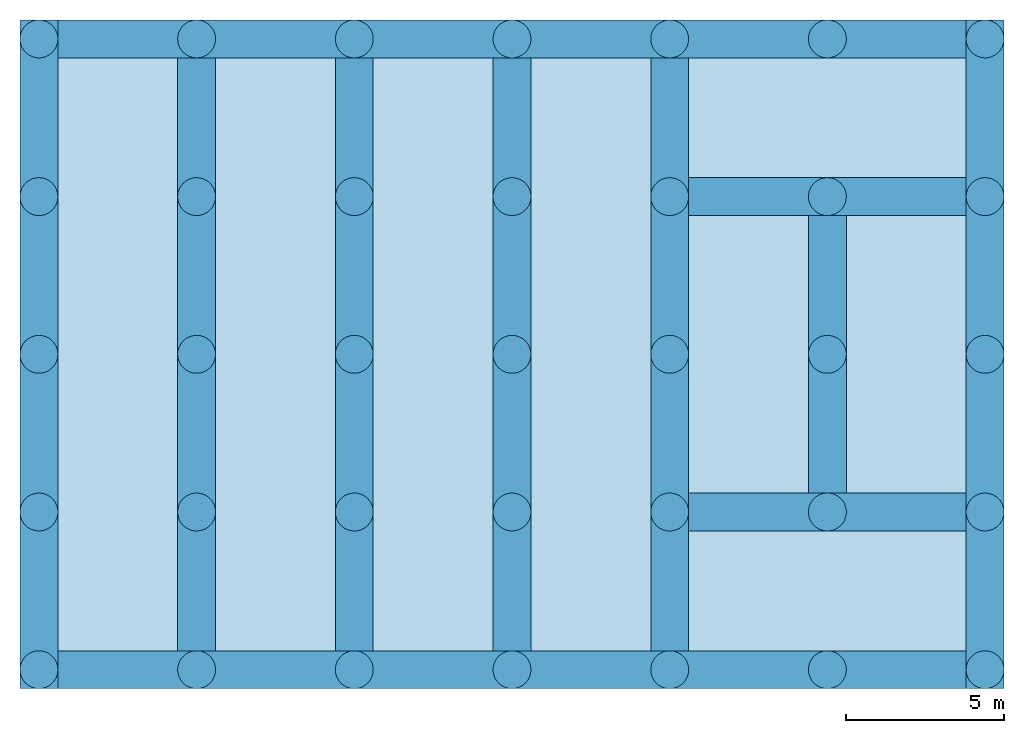
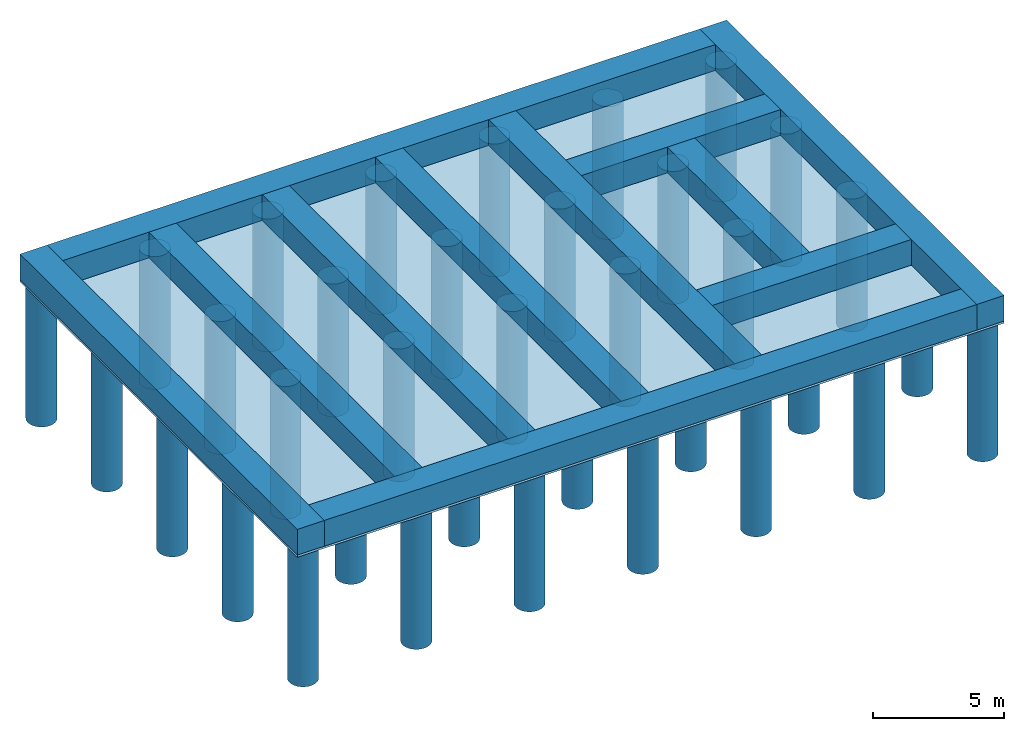
# One storey: 46 footings, 1 slab.
"""IFC2X3 building model written with IfcOpenShell, lengths in metres."""

from ifc_helpers import new_model, entity, si_unit, converted_unit, frame, frame_2d, origin, origin_with_axes, place, context, subcontext, project, spatial, rectangle, circle, extrude, material, element, save


model = new_model("IFC2X3")

# Units and contexts
model_context = context("Model", 3, precision=1e-05, world=origin())
body_context = subcontext(model_context, "Body", "Model", "MODEL_VIEW")
ifc_project = project(units=[si_unit("LENGTHUNIT", "METRE"), si_unit("AREAUNIT", "SQUARE_METRE"), si_unit("VOLUMEUNIT", "CUBIC_METRE"), si_unit("MASSUNIT", "GRAM", prefix="KILO"), converted_unit("PLANEANGLEUNIT", "DEGREE", entity("IfcPlaneAngleMeasure", 0.0174532925199433), si_unit("PLANEANGLEUNIT", "RADIAN"), dimensions=[0, 0, 0, 0, 0, 0, 0])], contexts=[model_context])

# Site, building, storey
site_placement = place(None, origin())
site = spatial("IfcSite", under=ifc_project, at=site_placement, CompositionType="ELEMENT")
building_placement = place(site_placement, origin())
building = spatial("IfcBuilding", under=site, at=building_placement, CompositionType="ELEMENT")
storey_placement = place(building_placement, frame((0.0, 0.0, -4.7)))
storey = spatial("IfcBuildingStorey", under=building, at=storey_placement, CompositionType="ELEMENT", Elevation=-4.7)

# Footings
ifc_material_1 = material(Name="C25/30")
footing_1_placement = place(storey_placement, frame((0.8, 19.6, 0.0)))
element("IfcFooting", 1, at=footing_1_placement, inside=storey, material=ifc_material_1, PredefinedType="STRIP_FOOTING", context=body_context, shape_type="SweptSolid", body=[
    extrude(rectangle(XDim=1.2, YDim=1.2, at=frame_2d((0.6, 0.6), x_axis=(1.0, 0.0))), frame((0.0, 0.0, 0.0), z_axis=(1.0, 0.0, 0.0), x_axis=(0.0, 1.0, 0.0)), (0.0, 0.0, 1.0), 28.8),
])
ifc_material_2 = material(Name="C25/30")
footing_2_placement = place(storey_placement, frame((0.8, -0.4, 0.0), z_axis=(0.0, 0.0, 1.0), x_axis=(0.0, 1.0, 0.0)))
element("IfcFooting", 2, at=footing_2_placement, inside=storey, material=ifc_material_2, PredefinedType="STRIP_FOOTING", context=body_context, shape_type="SweptSolid", body=[
    extrude(rectangle(XDim=1.2, YDim=1.2, at=frame_2d((0.6, 0.6), x_axis=(1.0, 0.0))), frame((0.0, 0.0, 0.0), z_axis=(1.0, 0.0, 0.0), x_axis=(0.0, 1.0, 0.0)), (0.0, 0.0, 1.0), 21.2),
])
ifc_material_3 = material(Name="C25/30")
footing_3_placement = place(storey_placement, frame((29.6, 0.8, 0.0), z_axis=(0.0, 0.0, 1.0), x_axis=(-1.0, 0.0, 0.0)))
element("IfcFooting", 3, at=footing_3_placement, inside=storey, material=ifc_material_3, PredefinedType="STRIP_FOOTING", context=body_context, shape_type="SweptSolid", body=[
    extrude(rectangle(XDim=1.2, YDim=1.2, at=frame_2d((0.6, 0.6), x_axis=(1.0, 0.0))), frame((0.0, 0.0, 0.0), z_axis=(1.0, 0.0, 0.0), x_axis=(0.0, 1.0, 0.0)), (0.0, 0.0, 1.0), 28.8),
])
ifc_material_4 = material(Name="C25/30")
footing_4_placement = place(storey_placement, frame((29.6, 20.8, 0.0), z_axis=(0.0, 0.0, 1.0), x_axis=(0.0, -1.0, 0.0)))
element("IfcFooting", 4, at=footing_4_placement, inside=storey, material=ifc_material_4, PredefinedType="STRIP_FOOTING", context=body_context, shape_type="SweptSolid", body=[
    extrude(rectangle(XDim=1.2, YDim=1.2, at=frame_2d((0.6, 0.6), x_axis=(1.0, 0.0))), frame((0.0, 0.0, 0.0), z_axis=(1.0, 0.0, 0.0), x_axis=(0.0, 1.0, 0.0)), (0.0, 0.0, 1.0), 21.2),
])
ifc_material_5 = material(Name="C25/30")
footing_5_placement = place(storey_placement, frame((20.8, 0.8, 0.0), z_axis=(0.0, 0.0, 1.0), x_axis=(0.0, 1.0, 0.0)))
element("IfcFooting", 5, at=footing_5_placement, inside=storey, material=ifc_material_5, PredefinedType="STRIP_FOOTING", context=body_context, shape_type="SweptSolid", body=[
    extrude(rectangle(XDim=1.2, YDim=1.2, at=frame_2d((0.6, 0.6), x_axis=(1.0, 0.0))), frame((0.0, 0.0, 0.0), z_axis=(1.0, 0.0, 0.0), x_axis=(0.0, 1.0, 0.0)), (0.0, 0.0, 1.0), 18.8),
])
ifc_material_6 = material(Name="C25/30")
footing_6_placement = place(storey_placement, frame((15.8, 0.8, 0.0), z_axis=(0.0, 0.0, 1.0), x_axis=(0.0, 1.0, 0.0)))
element("IfcFooting", 6, at=footing_6_placement, inside=storey, material=ifc_material_6, PredefinedType="STRIP_FOOTING", context=body_context, shape_type="SweptSolid", body=[
    extrude(rectangle(XDim=1.2, YDim=1.2, at=frame_2d((0.6, 0.6), x_axis=(1.0, 0.0))), frame((0.0, 0.0, 0.0), z_axis=(1.0, 0.0, 0.0), x_axis=(0.0, 1.0, 0.0)), (0.0, 0.0, 1.0), 18.8),
])
ifc_material_7 = material(Name="C25/30")
footing_7_placement = place(storey_placement, frame((10.8, 0.8, 0.0), z_axis=(0.0, 0.0, 1.0), x_axis=(0.0, 1.0, 0.0)))
element("IfcFooting", 7, at=footing_7_placement, inside=storey, material=ifc_material_7, PredefinedType="STRIP_FOOTING", context=body_context, shape_type="SweptSolid", body=[
    extrude(rectangle(XDim=1.2, YDim=1.2, at=frame_2d((0.600000000000002, 0.6), x_axis=(1.0, 0.0))), frame((0.0, 0.0, 0.0), z_axis=(1.0, 0.0, 0.0), x_axis=(0.0, 1.0, 0.0)), (0.0, 0.0, 1.0), 18.8),
])
ifc_material_8 = material(Name="C25/30")
footing_8_placement = place(storey_placement, frame((5.8, 0.8, 0.0), z_axis=(0.0, 0.0, 1.0), x_axis=(0.0, 1.0, 0.0)))
element("IfcFooting", 8, at=footing_8_placement, inside=storey, material=ifc_material_8, PredefinedType="STRIP_FOOTING", context=body_context, shape_type="SweptSolid", body=[
    extrude(rectangle(XDim=1.2, YDim=1.2, at=frame_2d((0.6, 0.6), x_axis=(1.0, 0.0))), frame((0.0, 0.0, 0.0), z_axis=(1.0, 0.0, 0.0), x_axis=(0.0, 1.0, 0.0)), (0.0, 0.0, 1.0), 18.8),
])
ifc_material_9 = material(Name="C25/30")
footing_9_placement = place(storey_placement, frame((24.6, 14.6, 0.0), z_axis=(0.0, 0.0, 1.0), x_axis=(0.0, -1.0, 0.0)))
element("IfcFooting", 9, at=footing_9_placement, inside=storey, material=ifc_material_9, PredefinedType="STRIP_FOOTING", context=body_context, shape_type="SweptSolid", body=[
    extrude(rectangle(XDim=1.2, YDim=1.2, at=frame_2d((0.6, 0.6), x_axis=(1.0, 0.0))), frame((0.0, 0.0, 0.0), z_axis=(1.0, 0.0, 0.0), x_axis=(0.0, 1.0, 0.0)), (0.0, 0.0, 1.0), 8.8),
])
ifc_material_10 = material(Name="C25/30")
footing_10_placement = place(storey_placement, frame((29.6, 5.8, 0.0), z_axis=(0.0, 0.0, 1.0), x_axis=(-1.0, 0.0, 0.0)))
element("IfcFooting", 10, at=footing_10_placement, inside=storey, material=ifc_material_10, PredefinedType="STRIP_FOOTING", context=body_context, shape_type="SweptSolid", body=[
    extrude(rectangle(XDim=1.2, YDim=1.2, at=frame_2d((0.6, 0.6), x_axis=(1.0, 0.0))), frame((0.0, 0.0, 0.0), z_axis=(1.0, 0.0, 0.0), x_axis=(0.0, 1.0, 0.0)), (0.0, 0.0, 1.0), 8.8),
])
ifc_material_11 = material(Name="C25/30")
footing_11_placement = place(storey_placement, frame((20.8, 14.6, 0.0)))
element("IfcFooting", 11, at=footing_11_placement, inside=storey, material=ifc_material_11, PredefinedType="STRIP_FOOTING", context=body_context, shape_type="SweptSolid", body=[
    extrude(rectangle(XDim=1.2, YDim=1.2, at=frame_2d((0.6, 0.6), x_axis=(1.0, 0.0))), frame((0.0, 0.0, 0.0), z_axis=(1.0, 0.0, 0.0), x_axis=(0.0, 1.0, 0.0)), (0.0, 0.0, 1.0), 8.8),
])
ifc_material_12 = material(Name="C25/30")
footing_12_placement = place(storey_placement, frame((9.60247658058307, 4.60247658058307, -6.3)))
element("IfcFooting", 12, at=footing_12_placement, inside=storey, material=ifc_material_12, PredefinedType="PAD_FOOTING", context=body_context, shape_type="SweptSolid", body=[
    extrude(circle(Radius=0.6, at=frame_2d((0.6, 0.6), x_axis=(1.0, 0.0))), frame((-0.00247658058306843, -0.00247658058306843, 0.0), z_axis=(0.0, 0.0, 1.0), x_axis=(1.0, 0.0, 0.0)), (0.0, 0.0, 1.0), 6.2),
])
ifc_material_13 = material(Name="C25/30")
footing_13_placement = place(storey_placement, frame((14.6024765805831, 4.60247658058307, -6.3)))
element("IfcFooting", 13, at=footing_13_placement, inside=storey, material=ifc_material_13, PredefinedType="PAD_FOOTING", context=body_context, shape_type="SweptSolid", body=[
    extrude(circle(Radius=0.6, at=frame_2d((0.6, 0.6), x_axis=(1.0, 0.0))), frame((-0.00247658058306843, -0.00247658058306843, 0.0), z_axis=(0.0, 0.0, 1.0), x_axis=(1.0, 0.0, 0.0)), (0.0, 0.0, 1.0), 6.2),
])
ifc_material_14 = material(Name="C25/30")
footing_14_placement = place(storey_placement, frame((19.6024765805831, 4.60247658058307, -6.3)))
element("IfcFooting", 14, at=footing_14_placement, inside=storey, material=ifc_material_14, PredefinedType="PAD_FOOTING", context=body_context, shape_type="SweptSolid", body=[
    extrude(circle(Radius=0.6, at=frame_2d((0.6, 0.6), x_axis=(1.0, 0.0))), frame((-0.00247658058306843, -0.00247658058306843, 0.0), z_axis=(0.0, 0.0, 1.0), x_axis=(1.0, 0.0, 0.0)), (0.0, 0.0, 1.0), 6.2),
])
ifc_material_15 = material(Name="C25/30")
footing_15_placement = place(storey_placement, frame((24.6024765805831, 4.60247658058307, -6.3)))
element("IfcFooting", 15, at=footing_15_placement, inside=storey, material=ifc_material_15, PredefinedType="PAD_FOOTING", context=body_context, shape_type="SweptSolid", body=[
    extrude(circle(Radius=0.6, at=frame_2d((0.6, 0.6), x_axis=(1.0, 0.0))), frame((-0.00247658058306843, -0.00247658058306843, 0.0), z_axis=(0.0, 0.0, 1.0), x_axis=(1.0, 0.0, 0.0)), (0.0, 0.0, 1.0), 6.2),
])
ifc_material_16 = material(Name="C25/30")
footing_16_placement = place(storey_placement, frame((29.6024765805831, 4.60247658058307, -6.3)))
element("IfcFooting", 16, at=footing_16_placement, inside=storey, material=ifc_material_16, PredefinedType="PAD_FOOTING", context=body_context, shape_type="SweptSolid", body=[
    extrude(circle(Radius=0.6, at=frame_2d((0.6, 0.6), x_axis=(1.0, 0.0))), frame((-0.00247658058306843, -0.00247658058306843, 0.0), z_axis=(0.0, 0.0, 1.0), x_axis=(1.0, 0.0, 0.0)), (0.0, 0.0, 1.0), 6.2),
])
ifc_material_17 = material(Name="C25/30")
footing_17_placement = place(storey_placement, frame((9.60247658058307, -0.397523419416931, -6.3)))
element("IfcFooting", 17, at=footing_17_placement, inside=storey, material=ifc_material_17, PredefinedType="PAD_FOOTING", context=body_context, shape_type="SweptSolid", body=[
    extrude(circle(Radius=0.6, at=frame_2d((0.6, 0.6), x_axis=(1.0, 0.0))), frame((-0.00247658058306843, -0.00247658058306877, 0.0), z_axis=(0.0, 0.0, 1.0), x_axis=(1.0, 0.0, 0.0)), (0.0, 0.0, 1.0), 6.2),
])
ifc_material_18 = material(Name="C25/30")
footing_18_placement = place(storey_placement, frame((14.6024765805831, -0.397523419416931, -6.3)))
element("IfcFooting", 18, at=footing_18_placement, inside=storey, material=ifc_material_18, PredefinedType="PAD_FOOTING", context=body_context, shape_type="SweptSolid", body=[
    extrude(circle(Radius=0.6, at=frame_2d((0.6, 0.6), x_axis=(1.0, 0.0))), frame((-0.00247658058306843, -0.00247658058306877, 0.0), z_axis=(0.0, 0.0, 1.0), x_axis=(1.0, 0.0, 0.0)), (0.0, 0.0, 1.0), 6.2),
])
ifc_material_19 = material(Name="C25/30")
footing_19_placement = place(storey_placement, frame((19.6024765805831, -0.397523419416931, -6.3)))
element("IfcFooting", 19, at=footing_19_placement, inside=storey, material=ifc_material_19, PredefinedType="PAD_FOOTING", context=body_context, shape_type="SweptSolid", body=[
    extrude(circle(Radius=0.6, at=frame_2d((0.6, 0.6), x_axis=(1.0, 0.0))), frame((-0.00247658058306843, -0.00247658058306877, 0.0), z_axis=(0.0, 0.0, 1.0), x_axis=(1.0, 0.0, 0.0)), (0.0, 0.0, 1.0), 6.2),
])
ifc_material_20 = material(Name="C25/30")
footing_20_placement = place(storey_placement, frame((24.6024765805831, -0.397523419416931, -6.3)))
element("IfcFooting", 20, at=footing_20_placement, inside=storey, material=ifc_material_20, PredefinedType="PAD_FOOTING", context=body_context, shape_type="SweptSolid", body=[
    extrude(circle(Radius=0.6, at=frame_2d((0.6, 0.6), x_axis=(1.0, 0.0))), frame((-0.00247658058306843, -0.00247658058306877, 0.0), z_axis=(0.0, 0.0, 1.0), x_axis=(1.0, 0.0, 0.0)), (0.0, 0.0, 1.0), 6.2),
])
ifc_material_21 = material(Name="C25/30")
footing_21_placement = place(storey_placement, frame((29.6024765805831, -0.397523419416931, -6.3)))
element("IfcFooting", 21, at=footing_21_placement, inside=storey, material=ifc_material_21, PredefinedType="PAD_FOOTING", context=body_context, shape_type="SweptSolid", body=[
    extrude(circle(Radius=0.6, at=frame_2d((0.6, 0.6), x_axis=(1.0, 0.0))), frame((-0.00247658058306843, -0.00247658058306877, 0.0), z_axis=(0.0, 0.0, 1.0), x_axis=(1.0, 0.0, 0.0)), (0.0, 0.0, 1.0), 6.2),
])
ifc_material_22 = material(Name="C25/30")
footing_22_placement = place(storey_placement, frame((9.60247658058307, 9.60247658058307, -6.3)))
element("IfcFooting", 22, at=footing_22_placement, inside=storey, material=ifc_material_22, PredefinedType="PAD_FOOTING", context=body_context, shape_type="SweptSolid", body=[
    extrude(circle(Radius=0.6, at=frame_2d((0.6, 0.6), x_axis=(1.0, 0.0))), frame((-0.00247658058306843, -0.00247658058306843, 0.0), z_axis=(0.0, 0.0, 1.0), x_axis=(1.0, 0.0, 0.0)), (0.0, 0.0, 1.0), 6.2),
])
ifc_material_23 = material(Name="C25/30")
footing_23_placement = place(storey_placement, frame((-0.397523419416931, 19.6024765805831, -6.3)))
element("IfcFooting", 23, at=footing_23_placement, inside=storey, material=ifc_material_23, PredefinedType="PAD_FOOTING", context=body_context, shape_type="SweptSolid", body=[
    extrude(circle(Radius=0.6, at=frame_2d((0.6, 0.6), x_axis=(1.0, 0.0))), frame((-0.00247658058306922, -0.00247658058306843, 0.0), z_axis=(0.0, 0.0, 1.0), x_axis=(1.0, 0.0, 0.0)), (0.0, 0.0, 1.0), 6.2),
])
ifc_material_24 = material(Name="C25/30")
footing_24_placement = place(storey_placement, frame((4.60247658058307, 4.60247658058307, -6.3)))
element("IfcFooting", 24, at=footing_24_placement, inside=storey, material=ifc_material_24, PredefinedType="PAD_FOOTING", context=body_context, shape_type="SweptSolid", body=[
    extrude(circle(Radius=0.6, at=frame_2d((0.6, 0.6), x_axis=(1.0, 0.0))), frame((-0.00247658058306843, -0.00247658058306843, 0.0), z_axis=(0.0, 0.0, 1.0), x_axis=(1.0, 0.0, 0.0)), (0.0, 0.0, 1.0), 6.2),
])
ifc_material_25 = material(Name="C25/30")
footing_25_placement = place(storey_placement, frame((4.60247658058307, 9.60247658058307, -6.3)))
element("IfcFooting", 25, at=footing_25_placement, inside=storey, material=ifc_material_25, PredefinedType="PAD_FOOTING", context=body_context, shape_type="SweptSolid", body=[
    extrude(circle(Radius=0.6, at=frame_2d((0.6, 0.6), x_axis=(1.0, 0.0))), frame((-0.00247658058306843, -0.00247658058306843, 0.0), z_axis=(0.0, 0.0, 1.0), x_axis=(1.0, 0.0, 0.0)), (0.0, 0.0, 1.0), 6.2),
])
ifc_material_26 = material(Name="C25/30")
footing_26_placement = place(storey_placement, frame((4.60247658058307, 14.6024765805831, -6.3)))
element("IfcFooting", 26, at=footing_26_placement, inside=storey, material=ifc_material_26, PredefinedType="PAD_FOOTING", context=body_context, shape_type="SweptSolid", body=[
    extrude(circle(Radius=0.6, at=frame_2d((0.6, 0.6), x_axis=(1.0, 0.0))), frame((-0.00247658058306843, -0.00247658058306843, 0.0), z_axis=(0.0, 0.0, 1.0), x_axis=(1.0, 0.0, 0.0)), (0.0, 0.0, 1.0), 6.2),
])
ifc_material_27 = material(Name="C25/30")
footing_27_placement = place(storey_placement, frame((4.60247658058307, 19.6024765805831, -6.3)))
element("IfcFooting", 27, at=footing_27_placement, inside=storey, material=ifc_material_27, PredefinedType="PAD_FOOTING", context=body_context, shape_type="SweptSolid", body=[
    extrude(circle(Radius=0.6, at=frame_2d((0.6, 0.6), x_axis=(1.0, 0.0))), frame((-0.00247658058306843, -0.00247658058306843, 0.0), z_axis=(0.0, 0.0, 1.0), x_axis=(1.0, 0.0, 0.0)), (0.0, 0.0, 1.0), 6.2),
])
ifc_material_28 = material(Name="C25/30")
footing_28_placement = place(storey_placement, frame((9.60247658058307, 14.6024765805831, -6.3)))
element("IfcFooting", 28, at=footing_28_placement, inside=storey, material=ifc_material_28, PredefinedType="PAD_FOOTING", context=body_context, shape_type="SweptSolid", body=[
    extrude(circle(Radius=0.6, at=frame_2d((0.6, 0.6), x_axis=(1.0, 0.0))), frame((-0.00247658058306843, -0.00247658058306843, 0.0), z_axis=(0.0, 0.0, 1.0), x_axis=(1.0, 0.0, 0.0)), (0.0, 0.0, 1.0), 6.2),
])
ifc_material_29 = material(Name="C25/30")
footing_29_placement = place(storey_placement, frame((9.60247658058307, 19.6024765805831, -6.3)))
element("IfcFooting", 29, at=footing_29_placement, inside=storey, material=ifc_material_29, PredefinedType="PAD_FOOTING", context=body_context, shape_type="SweptSolid", body=[
    extrude(circle(Radius=0.6, at=frame_2d((0.6, 0.6), x_axis=(1.0, 0.0))), frame((-0.00247658058306843, -0.00247658058306843, 0.0), z_axis=(0.0, 0.0, 1.0), x_axis=(1.0, 0.0, 0.0)), (0.0, 0.0, 1.0), 6.2),
])
ifc_material_30 = material(Name="C25/30")
footing_30_placement = place(storey_placement, frame((14.6024765805831, 9.60247658058307, -6.3)))
element("IfcFooting", 30, at=footing_30_placement, inside=storey, material=ifc_material_30, PredefinedType="PAD_FOOTING", context=body_context, shape_type="SweptSolid", body=[
    extrude(circle(Radius=0.6, at=frame_2d((0.6, 0.6), x_axis=(1.0, 0.0))), frame((-0.00247658058306843, -0.00247658058306843, 0.0), z_axis=(0.0, 0.0, 1.0), x_axis=(1.0, 0.0, 0.0)), (0.0, 0.0, 1.0), 6.2),
])
ifc_material_31 = material(Name="C25/30")
footing_31_placement = place(storey_placement, frame((14.6024765805831, 14.6024765805831, -6.3)))
element("IfcFooting", 31, at=footing_31_placement, inside=storey, material=ifc_material_31, PredefinedType="PAD_FOOTING", context=body_context, shape_type="SweptSolid", body=[
    extrude(circle(Radius=0.6, at=frame_2d((0.6, 0.6), x_axis=(1.0, 0.0))), frame((-0.00247658058306843, -0.00247658058306843, 0.0), z_axis=(0.0, 0.0, 1.0), x_axis=(1.0, 0.0, 0.0)), (0.0, 0.0, 1.0), 6.2),
])
ifc_material_32 = material(Name="C25/30")
footing_32_placement = place(storey_placement, frame((14.6024765805831, 19.6024765805831, -6.3)))
element("IfcFooting", 32, at=footing_32_placement, inside=storey, material=ifc_material_32, PredefinedType="PAD_FOOTING", context=body_context, shape_type="SweptSolid", body=[
    extrude(circle(Radius=0.6, at=frame_2d((0.6, 0.6), x_axis=(1.0, 0.0))), frame((-0.00247658058306843, -0.00247658058306843, 0.0), z_axis=(0.0, 0.0, 1.0), x_axis=(1.0, 0.0, 0.0)), (0.0, 0.0, 1.0), 6.2),
])
ifc_material_33 = material(Name="C25/30")
footing_33_placement = place(storey_placement, frame((19.6024765805831, 9.60247658058307, -6.3)))
element("IfcFooting", 33, at=footing_33_placement, inside=storey, material=ifc_material_33, PredefinedType="PAD_FOOTING", context=body_context, shape_type="SweptSolid", body=[
    extrude(circle(Radius=0.6, at=frame_2d((0.6, 0.6), x_axis=(1.0, 0.0))), frame((-0.00247658058306843, -0.00247658058306843, 0.0), z_axis=(0.0, 0.0, 1.0), x_axis=(1.0, 0.0, 0.0)), (0.0, 0.0, 1.0), 6.2),
])
ifc_material_34 = material(Name="C25/30")
footing_34_placement = place(storey_placement, frame((19.6024765805831, 14.6024765805831, -6.3)))
element("IfcFooting", 34, at=footing_34_placement, inside=storey, material=ifc_material_34, PredefinedType="PAD_FOOTING", context=body_context, shape_type="SweptSolid", body=[
    extrude(circle(Radius=0.6, at=frame_2d((0.6, 0.6), x_axis=(1.0, 0.0))), frame((-0.00247658058306843, -0.00247658058306843, 0.0), z_axis=(0.0, 0.0, 1.0), x_axis=(1.0, 0.0, 0.0)), (0.0, 0.0, 1.0), 6.2),
])
ifc_material_35 = material(Name="C25/30")
footing_35_placement = place(storey_placement, frame((19.6024765805831, 19.6024765805831, -6.3)))
element("IfcFooting", 35, at=footing_35_placement, inside=storey, material=ifc_material_35, PredefinedType="PAD_FOOTING", context=body_context, shape_type="SweptSolid", body=[
    extrude(circle(Radius=0.6, at=frame_2d((0.6, 0.6), x_axis=(1.0, 0.0))), frame((-0.00247658058306843, -0.00247658058306843, 0.0), z_axis=(0.0, 0.0, 1.0), x_axis=(1.0, 0.0, 0.0)), (0.0, 0.0, 1.0), 6.2),
])
ifc_material_36 = material(Name="C25/30")
footing_36_placement = place(storey_placement, frame((24.6024765805831, 9.60247658058307, -6.3)))
element("IfcFooting", 36, at=footing_36_placement, inside=storey, material=ifc_material_36, PredefinedType="PAD_FOOTING", context=body_context, shape_type="SweptSolid", body=[
    extrude(circle(Radius=0.6, at=frame_2d((0.6, 0.6), x_axis=(1.0, 0.0))), frame((-0.00247658058306843, -0.00247658058306843, 0.0), z_axis=(0.0, 0.0, 1.0), x_axis=(1.0, 0.0, 0.0)), (0.0, 0.0, 1.0), 6.2),
])
ifc_material_37 = material(Name="C25/30")
footing_37_placement = place(storey_placement, frame((24.6024765805831, 14.6024765805831, -6.3)))
element("IfcFooting", 37, at=footing_37_placement, inside=storey, material=ifc_material_37, PredefinedType="PAD_FOOTING", context=body_context, shape_type="SweptSolid", body=[
    extrude(circle(Radius=0.6, at=frame_2d((0.6, 0.6), x_axis=(1.0, 0.0))), frame((-0.00247658058306843, -0.00247658058306843, 0.0), z_axis=(0.0, 0.0, 1.0), x_axis=(1.0, 0.0, 0.0)), (0.0, 0.0, 1.0), 6.2),
])
ifc_material_38 = material(Name="C25/30")
footing_38_placement = place(storey_placement, frame((24.6024765805831, 19.6024765805831, -6.3)))
element("IfcFooting", 38, at=footing_38_placement, inside=storey, material=ifc_material_38, PredefinedType="PAD_FOOTING", context=body_context, shape_type="SweptSolid", body=[
    extrude(circle(Radius=0.6, at=frame_2d((0.6, 0.6), x_axis=(1.0, 0.0))), frame((-0.00247658058306843, -0.00247658058306843, 0.0), z_axis=(0.0, 0.0, 1.0), x_axis=(1.0, 0.0, 0.0)), (0.0, 0.0, 1.0), 6.2),
])
ifc_material_39 = material(Name="C25/30")
footing_39_placement = place(storey_placement, frame((29.6024765805831, 9.60247658058307, -6.3)))
element("IfcFooting", 39, at=footing_39_placement, inside=storey, material=ifc_material_39, PredefinedType="PAD_FOOTING", context=body_context, shape_type="SweptSolid", body=[
    extrude(circle(Radius=0.6, at=frame_2d((0.6, 0.6), x_axis=(1.0, 0.0))), frame((-0.00247658058306843, -0.00247658058306843, 0.0), z_axis=(0.0, 0.0, 1.0), x_axis=(1.0, 0.0, 0.0)), (0.0, 0.0, 1.0), 6.2),
])
ifc_material_40 = material(Name="C25/30")
footing_40_placement = place(storey_placement, frame((29.6024765805831, 14.6024765805831, -6.3)))
element("IfcFooting", 40, at=footing_40_placement, inside=storey, material=ifc_material_40, PredefinedType="PAD_FOOTING", context=body_context, shape_type="SweptSolid", body=[
    extrude(circle(Radius=0.6, at=frame_2d((0.6, 0.6), x_axis=(1.0, 0.0))), frame((-0.00247658058306843, -0.00247658058306843, 0.0), z_axis=(0.0, 0.0, 1.0), x_axis=(1.0, 0.0, 0.0)), (0.0, 0.0, 1.0), 6.2),
])
ifc_material_41 = material(Name="C25/30")
footing_41_placement = place(storey_placement, frame((29.6024765805831, 19.6024765805831, -6.3)))
element("IfcFooting", 41, at=footing_41_placement, inside=storey, material=ifc_material_41, PredefinedType="PAD_FOOTING", context=body_context, shape_type="SweptSolid", body=[
    extrude(circle(Radius=0.6, at=frame_2d((0.6, 0.6), x_axis=(1.0, 0.0))), frame((-0.00247658058306843, -0.00247658058306843, 0.0), z_axis=(0.0, 0.0, 1.0), x_axis=(1.0, 0.0, 0.0)), (0.0, 0.0, 1.0), 6.2),
])
ifc_material_42 = material(Name="C25/30")
footing_42_placement = place(storey_placement, frame((-0.397523419416931, 9.60247658058307, -6.3)))
element("IfcFooting", 42, at=footing_42_placement, inside=storey, material=ifc_material_42, PredefinedType="PAD_FOOTING", context=body_context, shape_type="SweptSolid", body=[
    extrude(circle(Radius=0.6, at=frame_2d((0.6, 0.6), x_axis=(1.0, 0.0))), frame((-0.00247658058306922, -0.00247658058306843, 0.0), z_axis=(0.0, 0.0, 1.0), x_axis=(1.0, 0.0, 0.0)), (0.0, 0.0, 1.0), 6.2),
])
ifc_material_43 = material(Name="C25/30")
footing_43_placement = place(storey_placement, frame((-0.397523419416931, 4.60247658058307, -6.3)))
element("IfcFooting", 43, at=footing_43_placement, inside=storey, material=ifc_material_43, PredefinedType="PAD_FOOTING", context=body_context, shape_type="SweptSolid", body=[
    extrude(circle(Radius=0.6, at=frame_2d((0.6, 0.6), x_axis=(1.0, 0.0))), frame((-0.00247658058306922, -0.00247658058306843, 0.0), z_axis=(0.0, 0.0, 1.0), x_axis=(1.0, 0.0, 0.0)), (0.0, 0.0, 1.0), 6.2),
])
ifc_material_44 = material(Name="C25/30")
footing_44_placement = place(storey_placement, frame((-0.397523419416931, -0.397523419416931, -6.3)))
element("IfcFooting", 44, at=footing_44_placement, inside=storey, material=ifc_material_44, PredefinedType="PAD_FOOTING", context=body_context, shape_type="SweptSolid", body=[
    extrude(circle(Radius=0.6, at=frame_2d((0.6, 0.6), x_axis=(1.0, 0.0))), frame((-0.00247658058306877, -0.00247658058306877, 0.0), z_axis=(0.0, 0.0, 1.0), x_axis=(1.0, 0.0, 0.0)), (0.0, 0.0, 1.0), 6.2),
])
ifc_material_45 = material(Name="C25/30")
footing_45_placement = place(storey_placement, frame((-0.397523419416931, 14.6024765805831, -6.3)))
element("IfcFooting", 45, at=footing_45_placement, inside=storey, material=ifc_material_45, PredefinedType="PAD_FOOTING", context=body_context, shape_type="SweptSolid", body=[
    extrude(circle(Radius=0.6, at=frame_2d((0.6, 0.6), x_axis=(1.0, 0.0))), frame((-0.00247658058306922, -0.00247658058306843, 0.0), z_axis=(0.0, 0.0, 1.0), x_axis=(1.0, 0.0, 0.0)), (0.0, 0.0, 1.0), 6.2),
])
ifc_material_46 = material(Name="C25/30")
footing_46_placement = place(storey_placement, frame((4.60247658058307, -0.397523419416931, -6.3)))
element("IfcFooting", 46, at=footing_46_placement, inside=storey, material=ifc_material_46, PredefinedType="PAD_FOOTING", context=body_context, shape_type="SweptSolid", body=[
    extrude(circle(Radius=0.6, at=frame_2d((0.6, 0.6), x_axis=(1.0, 0.0))), frame((-0.00247658058306843, -0.00247658058306877, 0.0), z_axis=(0.0, 0.0, 1.0), x_axis=(1.0, 0.0, 0.0)), (0.0, 0.0, 1.0), 6.2),
])

# Slab
ifc_material_47 = material(Name="C8/10")
slab_placement = place(storey_placement, frame((-0.4, -0.4, -0.1)))
element("IfcSlab", 47, at=slab_placement, inside=storey, material=ifc_material_47, PredefinedType="BASESLAB", context=body_context, shape_type="SweptSolid", body=[
    extrude(rectangle(XDim=31.2, YDim=21.2, at=frame_2d((15.6, 10.6), x_axis=(1.0, 0.0))), origin_with_axes(), (0.0, 0.0, 1.0), 0.1),
])

save(model, "model.ifc")
